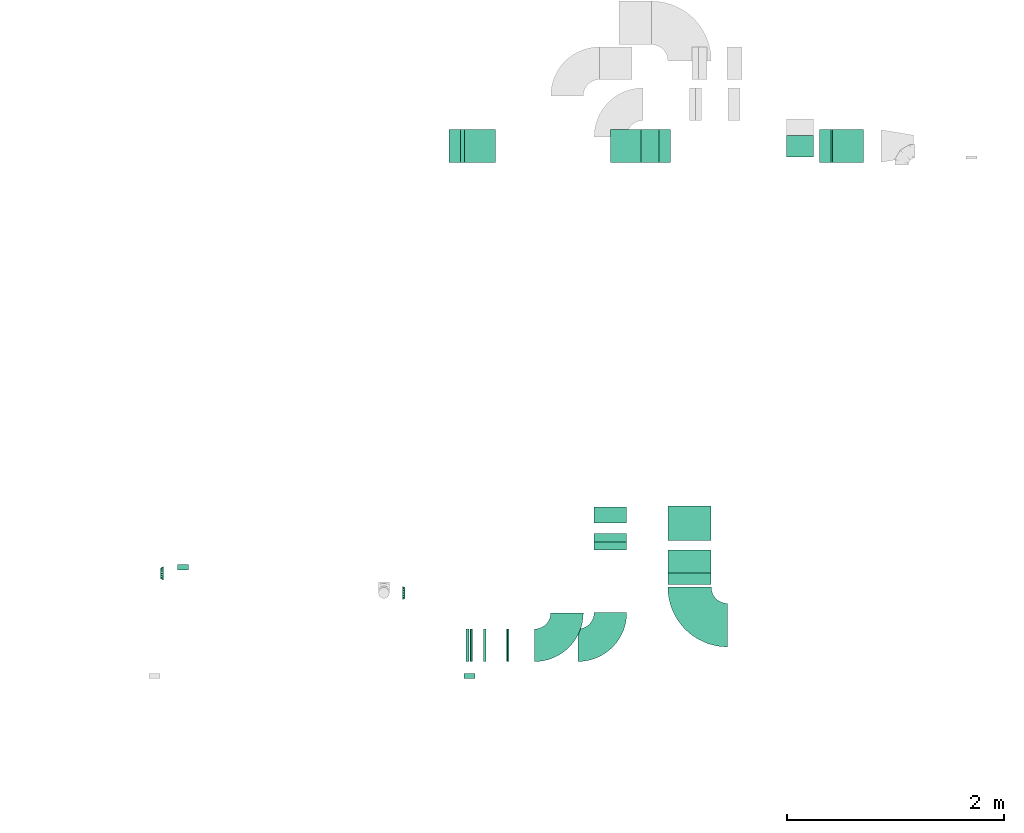
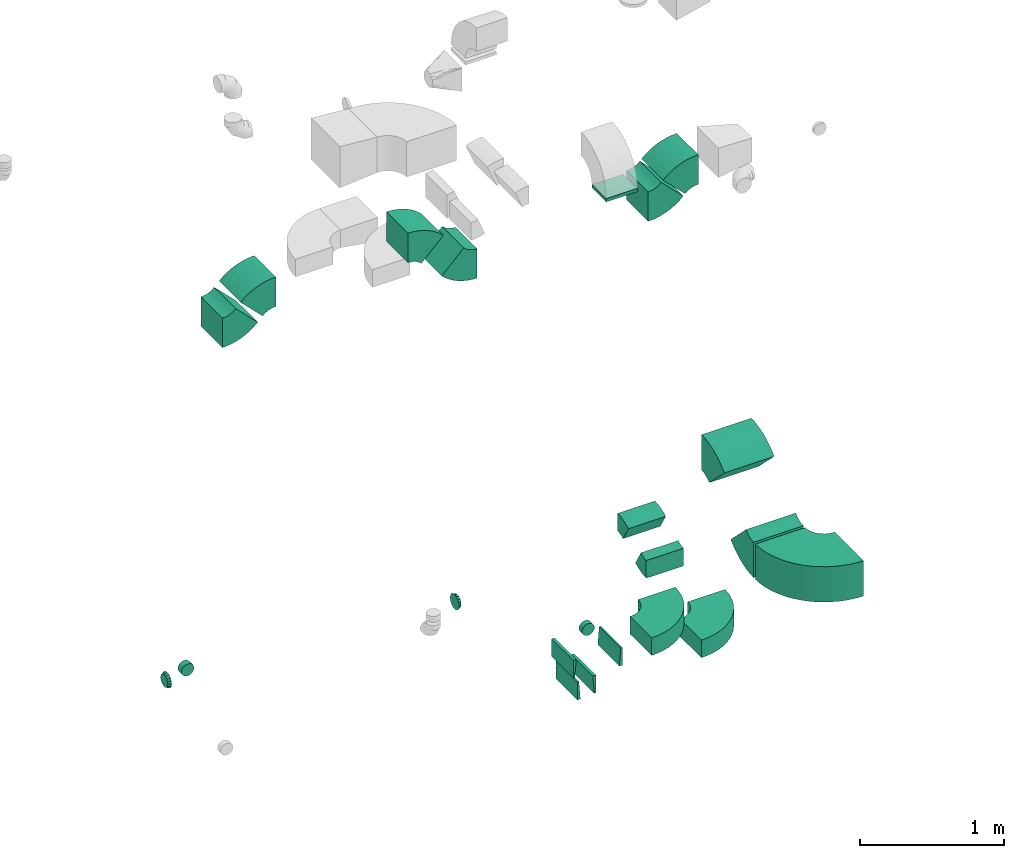
# One storey, part 19 of 44: 22 flow fittings.
"""IFC2X3 building model written with IfcOpenShell, lengths in millimetres."""

import ifcopenshell
import ifcopenshell.guid

model = None  # the IFC model being written
_history = None  # IfcOwnerHistory: only IFC2X3 demands one
_inside = {}  # id of a spatial element -> (the spatial element, [elements in it])
_under = {}  # id of a project, library or spatial element -> (it, [spatial elements below it])
_declared = {}  # id of a project -> (the project, [libraries it declares])
_typed = {}  # id of a type object -> (the type object, [elements of that type])
_made_of = {}  # id of a material, layer set ... -> (it, [elements and type objects made of it])


def new_model(schema):
    """Start an empty IFC model of exactly this schema.

    Asked for "IFC4X3", IfcOpenShell would pick the latest addendum, in which some entities
    have other attributes; the version numbers below select the first issue.
    IFC2X3 requires an IfcOwnerHistory on every rooted entity: one is made here for all.
    """
    global model, _history
    if schema == "IFC4X3":
        model = ifcopenshell.file(schema_version=(4, 3, 0, 0))
    else:
        model = ifcopenshell.file(schema=schema)
    _inside.clear()
    _under.clear()
    _declared.clear()
    _typed.clear()
    _made_of.clear()
    _history = None
    if model.schema == "IFC2X3":
        org = make("IfcOrganization", Name="unknown")
        user = make(
            "IfcPersonAndOrganization",
            ThePerson=make("IfcPerson", FamilyName="unknown"),
            TheOrganization=org,
        )
        app = make(
            "IfcApplication",
            ApplicationDeveloper=org,
            Version="unknown",
            ApplicationFullName="unknown",
            ApplicationIdentifier="unknown",
        )
        _history = make(
            "IfcOwnerHistory",
            OwningUser=user,
            OwningApplication=app,
            ChangeAction="ADDED",
            CreationDate=0,
        )
    return model


def make(cls, **values):
    """One entity of the class cls with the attributes given. An attribute that is None is left unset."""
    return model.create_entity(
        cls, **{name: value for name, value in values.items() if value is not None}
    )


def entity(cls, *values):
    """Any entity or typed value of the class cls, its attributes in the order of the schema. None: left unset."""
    e = model.create_entity(cls)
    for i, value in enumerate(values):
        if value is not None:
            e[i] = value
    return e


def rooted(cls, **values):
    """An entity with a GlobalId (a new one), such as an element, a storey or a relation."""
    return make(cls, GlobalId=ifcopenshell.guid.new(), OwnerHistory=_history, **values)


def si_unit(unit_type, name, prefix=None):
    """IfcSIUnit, for example si_unit("LENGTHUNIT", "METRE", prefix="MILLI")."""
    return make("IfcSIUnit", UnitType=unit_type, Prefix=prefix, Name=name)


def converted_unit(unit_type, name, factor, base, dimensions=None, offset=None):
    """IfcConversionBasedUnit, such as the inch: factor (a typed value) times the base unit."""
    return make(
        "IfcConversionBasedUnit"
        if offset is None
        else "IfcConversionBasedUnitWithOffset",
        ConversionOffset=offset,
        Dimensions=None
        if dimensions is None
        else entity("IfcDimensionalExponents", *dimensions),
        UnitType=unit_type,
        Name=name,
        ConversionFactor=make(
            "IfcMeasureWithUnit", ValueComponent=factor, UnitComponent=base
        ),
    )


def derived_unit(unit_type, elements):
    """IfcDerivedUnit: a product of units, each with its exponent."""
    return make(
        "IfcDerivedUnit",
        Elements=[
            make("IfcDerivedUnitElement", Unit=unit, Exponent=power)
            for unit, power in elements
        ],
        UnitType=unit_type,
    )


def assignment(units):
    """IfcUnitAssignment: the units of a project."""
    return None if units is None else make("IfcUnitAssignment", Units=units)


def point(xyz):
    """IfcCartesianPoint."""
    return None if xyz is None else make("IfcCartesianPoint", Coordinates=xyz)


def direction(xyz):
    """IfcDirection."""
    return None if xyz is None else make("IfcDirection", DirectionRatios=xyz)


def frame(location, z_axis=None, x_axis=None):
    """IfcAxis2Placement3D, a coordinate frame: its origin and axes. An axis left out is left unset."""
    return make(
        "IfcAxis2Placement3D",
        Location=point(location),
        Axis=direction(z_axis),
        RefDirection=direction(x_axis),
    )


def frame_2d(location, x_axis=None):
    """IfcAxis2Placement2D, a coordinate frame in the plane: its origin and x axis."""
    return make(
        "IfcAxis2Placement2D", Location=point(location), RefDirection=direction(x_axis)
    )


def origin():
    """The frame at (0, 0, 0) with its axes left unset."""
    return frame((0.0, 0.0, 0.0))


def origin_2d_with_axis():
    """The frame at (0, 0) in the plane with the x axis (1, 0) written out."""
    return frame_2d((0.0, 0.0), x_axis=(1.0, 0.0))


def place(relative_to, where):
    """IfcLocalPlacement: puts the frame where relative to a parent placement (None: the world)."""
    return make(
        "IfcLocalPlacement", PlacementRelTo=relative_to, RelativePlacement=where
    )


def context(
    kind, dimensions, precision=None, world=None, true_north=None, identifier=None
):
    """IfcGeometricRepresentationContext, for example the 3D "Model" context."""
    return make(
        "IfcGeometricRepresentationContext",
        ContextIdentifier=identifier,
        ContextType=kind,
        CoordinateSpaceDimension=dimensions,
        Precision=precision,
        WorldCoordinateSystem=world,
        TrueNorth=true_north,
    )


def subcontext(parent, identifier, kind, view, scale=None):
    """IfcGeometricRepresentationSubContext, for example "Body" below "Model"."""
    return make(
        "IfcGeometricRepresentationSubContext",
        ContextIdentifier=identifier,
        ContextType=kind,
        ParentContext=parent,
        TargetScale=scale,
        TargetView=view,
    )


def project(units=None, contexts=None):
    """IfcProject with its units and contexts."""
    return rooted(
        "IfcProject",
        Name="project",
        RepresentationContexts=contexts,
        UnitsInContext=assignment(units),
    )


def spatial(cls, under=None, at=None, **own):
    """A site, building, storey or space (cls), placed at a placement, below another one or the project."""
    s = rooted(cls, ObjectPlacement=at, **own)
    if under is not None:
        _under.setdefault(under.id(), (under, []))[1].append(s)
    return s


def polyline(points):
    """IfcPolyline through the points."""
    return make("IfcPolyline", Points=[point(p) for p in points])


def circle_curve(where, radius):
    """IfcCircle in the frame where."""
    return make("IfcCircle", Position=where, Radius=radius)


def parameter(value):
    """IfcParameterValue: where a trimmed curve begins or ends, as a parameter of its basis curve."""
    return model.create_entity("IfcParameterValue", value)


def trimmed(basis, trim1, trim2, sense, master):
    """IfcTrimmedCurve: the piece of a basis curve between two trims."""
    return make(
        "IfcTrimmedCurve",
        BasisCurve=basis,
        Trim1=trim1,
        Trim2=trim2,
        SenseAgreement=sense,
        MasterRepresentation=master,
    )


def segment(curve, same_sense, transition):
    """IfcCompositeCurveSegment."""
    return make(
        "IfcCompositeCurveSegment",
        Transition=transition,
        SameSense=same_sense,
        ParentCurve=curve,
    )


def composite_curve(segments, self_intersect=None):
    """IfcCompositeCurve: segments joined end to end."""
    return make("IfcCompositeCurve", Segments=segments, SelfIntersect=self_intersect)


def profile(cls, at=None, kind="AREA", **sizes):
    """A parametric profile (cls). Its sizes go by their IFC names, for example OverallWidth=200.0."""
    return make(cls, ProfileType=kind, Position=at, **sizes)


def rectangle(**sizes):
    """IfcRectangleProfileDef."""
    return profile("IfcRectangleProfileDef", **sizes)


def outline(outer, holes=None, kind="AREA"):
    """IfcArbitraryClosedProfileDef: a profile drawn as a closed curve; with holes, ...WithVoids."""
    if holes is None:
        return make("IfcArbitraryClosedProfileDef", ProfileType=kind, OuterCurve=outer)
    return make(
        "IfcArbitraryProfileDefWithVoids",
        ProfileType=kind,
        OuterCurve=outer,
        InnerCurves=holes,
    )


def extrude(swept, where, along, depth):
    """IfcExtrudedAreaSolid: the profile swept, set in the frame where, extruded along a direction by depth."""
    return make(
        "IfcExtrudedAreaSolid",
        SweptArea=swept,
        Position=where,
        ExtrudedDirection=direction(along),
        Depth=depth,
    )


def faces_of(points, faces, orient=None, outer=None):
    """IfcFace entities. A face is a list of loops; a loop is a list of indices into points, from 0.

    orient and outer hold one flag for each loop. By default every Orientation is true, the
    first loop of a face is its IfcFaceOuterBound and the others are IfcFaceBound.
    """
    made = []
    for i, loops in enumerate(faces):
        bounds = []
        for j, loop in enumerate(loops):
            is_outer = j == 0 if outer is None else outer[i][j]
            bounds.append(
                make(
                    "IfcFaceOuterBound" if is_outer else "IfcFaceBound",
                    Bound=make("IfcPolyLoop", Polygon=[points[k] for k in loop]),
                    Orientation=True if orient is None else orient[i][j],
                )
            )
        made.append(make("IfcFace", Bounds=bounds))
    return made


def faceted_brep(points, faces, orient=None, outer=None, voids=None):
    """IfcFacetedBrep: a solid bounded by flat faces; with voids (closed shells), ...WithVoids."""
    shared = [point(p) for p in points]
    hull = make("IfcClosedShell", CfsFaces=faces_of(shared, faces, orient, outer))
    if voids is None:
        return make("IfcFacetedBrep", Outer=hull)
    return make(
        "IfcFacetedBrepWithVoids",
        Outer=hull,
        Voids=[
            make(cls, CfsFaces=faces_of(shared, fs, o, b)) for cls, fs, o, b in voids
        ],
    )


def shape(context_of_items, identifier, shape_type, items):
    """IfcShapeRepresentation: the items that make up one representation, for example the "Body"."""
    return make(
        "IfcShapeRepresentation",
        ContextOfItems=context_of_items,
        RepresentationIdentifier=identifier,
        RepresentationType=shape_type,
        Items=items,
    )


def source(mapping_origin, context_of_items, identifier, shape_type, items):
    """IfcRepresentationMap: a shape defined once, which mapped items show again and again."""
    return make(
        "IfcRepresentationMap",
        MappingOrigin=mapping_origin,
        MappedRepresentation=shape(context_of_items, identifier, shape_type, items),
    )


def transform(
    local_origin,
    x_axis=None,
    y_axis=None,
    z_axis=None,
    scale=None,
    scale2=None,
    scale3=None,
    uniform=True,
):
    """IfcCartesianTransformationOperator3D, or its non-uniform kind. x_axis, y_axis, z_axis: its Axis1, 2, 3."""
    if uniform:
        return make(
            "IfcCartesianTransformationOperator3D",
            Axis1=direction(x_axis),
            Axis2=direction(y_axis),
            LocalOrigin=point(local_origin),
            Scale=scale,
            Axis3=direction(z_axis),
        )
    return make(
        "IfcCartesianTransformationOperator3DnonUniform",
        Axis1=direction(x_axis),
        Axis2=direction(y_axis),
        LocalOrigin=point(local_origin),
        Scale=scale,
        Axis3=direction(z_axis),
        Scale2=scale2,
        Scale3=scale3,
    )


def mapped(mapping_source, mapping_target):
    """IfcMappedItem: shows the shape of a source again, moved by a transform."""
    return make(
        "IfcMappedItem", MappingSource=mapping_source, MappingTarget=mapping_target
    )


def material(Name=None, Category=None):
    """IfcMaterial."""
    return make("IfcMaterial", Name=Name, Category=Category)


def made_of(thing, what):
    """Note that an element or type object is made of a material, layer set ...; save() writes the relation."""
    if what is not None:
        _made_of.setdefault(what.id(), (what, []))[1].append(thing)
    return thing


def type_object(cls, material=None, **own):
    """A type object (cls), such as IfcWallType, which elements share."""
    return made_of(rooted(cls, **own), material)


def type_shapes(of_type, sources):
    """Give a type object the sources (RepresentationMaps) that its elements show as mapped items."""
    of_type.RepresentationMaps = sources


def element(
    cls,
    number,
    at=None,
    inside=None,
    cuts=None,
    type_object=None,
    material=None,
    context=None,
    identifier="Body",
    shape_type=None,
    held_by="IfcProductDefinitionShape",
    body=None,
    shapes=None,
    **own,
):
    """One element of the class cls, such as IfcWall. Its Tag is "e" and its number.

    at: its placement. inside: the storey or other place that contains it. cuts: it is an
    opening in that element (IfcRelVoidsElement). A single representation is given by context,
    identifier, shape_type and body (its items); several are given by shapes. held_by: the class
    of the entity that holds the representations. save() writes the other relations.
    """
    e = rooted(cls, Tag="e%d" % number, ObjectPlacement=at, **own)
    if body is not None:
        shapes = [shape(context, identifier, shape_type, body)]
    if shapes is not None:
        e.Representation = make(held_by, Representations=shapes)
    if inside is not None:
        _inside.setdefault(inside.id(), (inside, []))[1].append(e)
    if cuts is not None:
        rooted(
            "IfcRelVoidsElement", RelatingBuildingElement=cuts, RelatedOpeningElement=e
        )
    if type_object is not None:
        _typed.setdefault(type_object.id(), (type_object, []))[1].append(e)
    return made_of(e, material)


def aggregate(whole, parts):
    """IfcRelAggregates: a whole, such as a stair, and the parts it consists of."""
    return rooted("IfcRelAggregates", RelatingObject=whole, RelatedObjects=parts)


def save(model, path):
    """Write the relations noted so far, then the file.

    IfcRelAggregates (storeys below a building ...), IfcRelContainedInSpatialStructure (elements
    in a storey), IfcRelDefinesByType, IfcRelAssociatesMaterial and IfcRelDeclares: one each for
    every whole, place, type object, material and project.
    """
    for whole, parts in _under.values():
        aggregate(whole, parts)
    for where, things in _inside.values():
        rooted(
            "IfcRelContainedInSpatialStructure",
            RelatedElements=things,
            RelatingStructure=where,
        )
    for kind, things in _typed.values():
        rooted("IfcRelDefinesByType", RelatedObjects=things, RelatingType=kind)
    for what, things in _made_of.values():
        rooted("IfcRelAssociatesMaterial", RelatedObjects=things, RelatingMaterial=what)
    for by, libraries in _declared.values():
        rooted("IfcRelDeclares", RelatingContext=by, RelatedDefinitions=libraries)
    model.write(path)


model = new_model("IFC2X3")

# Units and contexts
model_context = context("Model", 3, precision=0.01, world=origin(), true_north=direction((6.12303176911189e-17, 1.0)))
body_context = subcontext(model_context, "Body", "Model", "MODEL_VIEW")
ifc_project = project(units=[si_unit("LENGTHUNIT", "METRE", prefix="MILLI"), si_unit("AREAUNIT", "SQUARE_METRE"), si_unit("VOLUMEUNIT", "CUBIC_METRE"), converted_unit("PLANEANGLEUNIT", "DEGREE", entity("IfcRatioMeasure", 0.0174532925199433), si_unit("PLANEANGLEUNIT", "RADIAN"), dimensions=[0, 0, 0, 0, 0, 0, 0]), si_unit("MASSUNIT", "GRAM", prefix="KILO"), derived_unit("MASSDENSITYUNIT", [(si_unit("MASSUNIT", "GRAM", prefix="KILO"), 1), (si_unit("LENGTHUNIT", "METRE"), -3)]), derived_unit("MOMENTOFINERTIAUNIT", [(si_unit("LENGTHUNIT", "METRE"), 4)]), si_unit("TIMEUNIT", "SECOND"), si_unit("FREQUENCYUNIT", "HERTZ"), si_unit("THERMODYNAMICTEMPERATUREUNIT", "DEGREE_CELSIUS"), derived_unit("THERMALTRANSMITTANCEUNIT", [(si_unit("MASSUNIT", "GRAM", prefix="KILO"), 1), (si_unit("THERMODYNAMICTEMPERATUREUNIT", "KELVIN"), -1), (si_unit("TIMEUNIT", "SECOND"), -3)]), derived_unit("VOLUMETRICFLOWRATEUNIT", [(si_unit("LENGTHUNIT", "METRE"), 3), (si_unit("TIMEUNIT", "SECOND"), -1)]), derived_unit("MASSFLOWRATEUNIT", [(si_unit("MASSUNIT", "GRAM", prefix="KILO"), 1), (si_unit("TIMEUNIT", "SECOND"), -1)]), derived_unit("ROTATIONALFREQUENCYUNIT", [(si_unit("TIMEUNIT", "SECOND"), -1)]), si_unit("ELECTRICCURRENTUNIT", "AMPERE"), si_unit("ELECTRICVOLTAGEUNIT", "VOLT"), si_unit("POWERUNIT", "WATT"), si_unit("FORCEUNIT", "NEWTON", prefix="KILO"), si_unit("ILLUMINANCEUNIT", "LUX"), si_unit("LUMINOUSFLUXUNIT", "LUMEN"), si_unit("LUMINOUSINTENSITYUNIT", "CANDELA"), derived_unit("USERDEFINED", [(si_unit("MASSUNIT", "GRAM", prefix="KILO"), -1), (si_unit("LENGTHUNIT", "METRE"), -2), (si_unit("TIMEUNIT", "SECOND"), 3), (si_unit("LUMINOUSFLUXUNIT", "LUMEN"), 1)]), derived_unit("LINEARVELOCITYUNIT", [(si_unit("LENGTHUNIT", "METRE"), 1), (si_unit("TIMEUNIT", "SECOND"), -1)]), si_unit("PRESSUREUNIT", "PASCAL"), derived_unit("USERDEFINED", [(si_unit("LENGTHUNIT", "METRE"), -2), (si_unit("MASSUNIT", "GRAM", prefix="KILO"), 1), (si_unit("TIMEUNIT", "SECOND"), -2)]), derived_unit("LINEARFORCEUNIT", [(si_unit("MASSUNIT", "GRAM", prefix="KILO"), 1), (si_unit("LENGTHUNIT", "METRE"), 1), (si_unit("TIMEUNIT", "SECOND"), -2), (si_unit("LENGTHUNIT", "METRE"), -1)]), derived_unit("PLANARFORCEUNIT", [(si_unit("MASSUNIT", "GRAM", prefix="KILO"), 1), (si_unit("LENGTHUNIT", "METRE"), 1), (si_unit("TIMEUNIT", "SECOND"), -2), (si_unit("LENGTHUNIT", "METRE"), -2)])], contexts=[model_context])

# Site, building, storey
site_placement = place(None, origin())
site = spatial("IfcSite", under=ifc_project, at=site_placement, CompositionType="ELEMENT")
building_placement = place(site_placement, origin())
building = spatial("IfcBuilding", under=site, at=building_placement, CompositionType="ELEMENT")
storey_placement = place(building_placement, frame((0.0, 0.0, 15900.0)))
storey = spatial("IfcBuildingStorey", under=building, at=storey_placement, CompositionType="ELEMENT", Elevation=15900.0)

# Flow fittings
ifc_material = material()
duct_fitting_type_1 = type_object("IfcDuctFittingType", PredefinedType="NOTDEFINED", material=ifc_material)
shared_shape_1 = source(origin(), body_context, "Body", "SweptSolid", [
    extrude(rectangle(XDim=26.096000000009, YDim=250.0, at=origin_2d_with_axis()), frame((6.95, 0.0, -100.0)), (0.0, 0.0, 1.0), 200.0),
])
type_shapes(duct_fitting_type_1, [shared_shape_1])
flow_fitting_1_placement = place(storey_placement, frame((39464.82, 14174.64, 3075.0), z_axis=(0.0, -1.0, 0.0), x_axis=(0.0, 0.0, 1.0)))
element("IfcFlowFitting", 1, at=flow_fitting_1_placement, inside=storey, type_object=duct_fitting_type_1, material=ifc_material, context=body_context, shape_type="MappedRepresentation", body=[
    mapped(shared_shape_1, transform((0.0, 0.0, 0.0), scale=1.0)),
])
duct_fitting_type_2 = type_object("IfcDuctFittingType", PredefinedType="NOTDEFINED", material=ifc_material)
shared_shape_2 = source(origin(), body_context, "Body", "Brep", [
    faceted_brep([(20.0, 12.94, -48.3), (20.0, 25.0, -43.3), (20.0, 35.36, -35.36), (20.0, 43.3, -25.0), (20.0, 48.3, -12.94), (20.0, 50.0, 0.0), (20.0, 48.3, 12.94), (20.0, 43.3, 25.0), (20.0, 35.36, 35.36), (20.0, 25.0, 43.3), (20.0, 12.94, 48.3), (20.0, 0.0, 50.0), (20.0, -12.94, 48.3), (20.0, -25.0, 43.3), (20.0, -35.36, 35.36), (20.0, -43.3, 25.0), (20.0, -48.3, 12.94), (20.0, -50.0, 0.0), (20.0, -48.3, -12.94), (20.0, -43.3, -25.0), (20.0, -35.36, -35.36), (20.0, -25.0, -43.3), (20.0, -12.94, -48.3), (20.0, 0.0, -50.0), (0.0, 0.0, 50.0), (0.0, 12.94, 48.3), (-23.65, 12.94, 48.3), (-23.65, 0.0, 50.0), (0.0, 25.0, 43.3), (-23.65, 25.0, 43.3), (0.0, 35.36, 35.36), (-23.65, 35.36, 35.36), (0.0, 43.3, 25.0), (0.0, 48.3, 12.94), (-23.65, 48.3, 12.94), (-23.65, 43.3, 25.0), (0.0, 50.0, 0.0), (-23.65, 50.0, 0.0), (0.0, 48.3, -12.94), (-23.65, 48.3, -12.94), (0.0, 43.3, -25.0), (-23.65, 43.3, -25.0), (0.0, 35.36, -35.36), (-23.65, 35.36, -35.36), (0.0, 25.0, -43.3), (0.0, 12.94, -48.3), (-23.65, 12.94, -48.3), (-23.65, 25.0, -43.3), (0.0, 0.0, -50.0), (-23.65, 0.0, -50.0), (0.0, -12.94, -48.3), (-23.65, -12.94, -48.3), (0.0, -25.0, -43.3), (-23.65, -25.0, -43.3), (0.0, -35.36, -35.36), (-23.65, -35.36, -35.36), (0.0, -43.3, -25.0), (0.0, -48.3, -12.94), (-23.65, -48.3, -12.94), (-23.65, -43.3, -25.0), (0.0, -50.0, 0.0), (-23.65, -50.0, 0.0), (0.0, -48.3, 12.94), (-23.65, -48.3, 12.94), (0.0, -43.3, 25.0), (-23.65, -43.3, 25.0), (0.0, -35.36, 35.36), (-23.65, -35.36, 35.36), (0.0, -25.0, 43.3), (0.0, -12.94, 48.3), (-23.65, -12.94, 48.3), (-23.65, -25.0, 43.3)], [[[0, 1, 2, 3, 4, 5, 6, 7, 8, 9, 10, 11, 12, 13, 14, 15, 16, 17, 18, 19, 20, 21, 22, 23]], [[24, 11, 10, 25, 26, 27]], [[25, 10, 9, 28, 29, 26]], [[28, 9, 8, 30, 31, 29]], [[32, 7, 6, 33, 34, 35]], [[33, 6, 5, 36, 37, 34]], [[30, 8, 7, 32, 35, 31]], [[36, 5, 4, 38, 39, 37]], [[38, 4, 3, 40, 41, 39]], [[40, 3, 2, 42, 43, 41]], [[44, 1, 0, 45, 46, 47]], [[45, 0, 23, 48, 49, 46]], [[42, 2, 1, 44, 47, 43]], [[48, 23, 22, 50, 51, 49]], [[50, 22, 21, 52, 53, 51]], [[52, 21, 20, 54, 55, 53]], [[56, 19, 18, 57, 58, 59]], [[57, 18, 17, 60, 61, 58]], [[54, 20, 19, 56, 59, 55]], [[60, 17, 16, 62, 63, 61]], [[62, 16, 15, 64, 65, 63]], [[64, 15, 14, 66, 67, 65]], [[68, 13, 12, 69, 70, 71]], [[69, 12, 11, 24, 27, 70]], [[66, 14, 13, 68, 71, 67]], [[49, 51, 53, 55, 59, 58, 61, 63, 65, 67, 71, 70, 27, 26, 29, 31, 35, 34, 37, 39, 41, 43, 47, 46]]]),
])
type_shapes(duct_fitting_type_2, [shared_shape_2])
flow_fitting_2_placement = place(storey_placement, frame((36421.31, 9290.12, 3375.0), z_axis=(0.0, 0.0, -1.0), x_axis=(0.0, -1.0, 0.0)))
element("IfcFlowFitting", 2, at=flow_fitting_2_placement, inside=storey, type_object=duct_fitting_type_2, material=ifc_material, context=body_context, shape_type="MappedRepresentation", body=[
    mapped(shared_shape_2, transform((0.0, 0.0, 0.0), scale=1.0)),
])
duct_fitting_type_3 = type_object("IfcDuctFittingType", PredefinedType="NOTDEFINED", material=ifc_material)
shared_shape_3 = source(origin(), body_context, "Body", "Brep", [
    faceted_brep([(25.0, -46.19, 19.13), (25.0, -48.1, 9.57), (25.0, -50.0, 0.0), (25.0, -48.1, -9.57), (25.0, -46.19, -19.13), (25.0, -40.77, -27.24), (25.0, -35.36, -35.36), (25.0, -27.24, -40.77), (25.0, -19.13, -46.19), (25.0, -9.57, -48.1), (25.0, 0.0, -50.0), (25.0, 9.57, -48.1), (25.0, 19.13, -46.19), (25.0, 27.24, -40.77), (25.0, 35.36, -35.36), (25.0, 40.77, -27.24), (25.0, 46.19, -19.13), (25.0, 48.1, -9.57), (25.0, 50.0, 0.0), (25.0, 48.1, 9.57), (25.0, 46.19, 19.13), (25.0, 40.77, 27.24), (25.0, 35.36, 35.36), (25.0, 27.24, 40.77), (25.0, 19.13, 46.19), (25.0, 9.57, 48.1), (25.0, 0.0, 50.0), (25.0, -9.57, 48.1), (25.0, -19.13, 46.19), (25.0, -27.24, 40.77), (25.0, -35.36, 35.36), (25.0, -40.77, 27.24), (0.0, -62.5, 0.0), (0.0, -60.02, 12.45), (0.0, -57.74, 23.92), (0.0, -50.97, 34.06), (0.0, -44.19, 44.19), (0.0, -34.06, 50.97), (0.0, -23.92, 57.74), (0.0, -12.45, 60.02), (0.0, 0.0, 62.5), (0.0, 12.45, 60.02), (0.0, 23.92, 57.74), (0.0, 34.06, 50.97), (0.0, 44.19, 44.19), (0.0, 50.97, 34.06), (0.0, 57.74, 23.92), (0.0, 60.02, 12.45), (0.0, 62.5, 0.0), (0.0, 60.02, -12.45), (0.0, 57.74, -23.92), (0.0, 50.97, -34.06), (0.0, 44.19, -44.19), (0.0, 34.06, -50.97), (0.0, 23.92, -57.74), (0.0, 12.45, -60.02), (0.0, 0.0, -62.5), (0.0, -12.45, -60.02), (0.0, -23.92, -57.74), (0.0, -34.06, -50.97), (0.0, -44.19, -44.19), (0.0, -50.97, -34.06), (0.0, -57.74, -23.92), (0.0, -60.02, -12.45)], [[[0, 1, 2, 3, 4, 5, 6, 7, 8, 9, 10, 11, 12, 13, 14, 15, 16, 17, 18, 19, 20, 21, 22, 23, 24, 25, 26, 27, 28, 29, 30, 31]], [[32, 33, 34, 35, 36, 37, 38, 39, 40, 41, 42, 43, 44, 45, 46, 47, 48, 49, 50, 51, 52, 53, 54, 55, 56, 57, 58, 59, 60, 61, 62, 63]], [[24, 42, 41, 40, 26, 25]], [[22, 44, 43, 42, 24, 23]], [[48, 47, 46, 20, 19, 18]], [[44, 22, 21, 20, 46, 45]], [[0, 34, 33, 32, 2, 1]], [[30, 36, 35, 34, 0, 31]], [[40, 39, 38, 28, 27, 26]], [[36, 30, 29, 28, 38, 37]], [[8, 58, 57, 56, 10, 9]], [[6, 60, 59, 58, 8, 7]], [[32, 63, 62, 4, 3, 2]], [[60, 6, 5, 4, 62, 61]], [[16, 50, 49, 48, 18, 17]], [[14, 52, 51, 50, 16, 15]], [[56, 55, 54, 12, 11, 10]], [[52, 14, 13, 12, 54, 53]]]),
])
type_shapes(duct_fitting_type_3, [shared_shape_3])
flow_fitting_3_placement = place(storey_placement, frame((33599.89, 10237.4, 3350.0), z_axis=(0.0, 0.0, 1.0), x_axis=(-1.0, 0.0, 0.0)))
element("IfcFlowFitting", 3, at=flow_fitting_3_placement, inside=storey, type_object=duct_fitting_type_3, material=ifc_material, context=body_context, shape_type="MappedRepresentation", body=[
    mapped(shared_shape_3, transform((0.0, 0.0, 0.0), scale=1.0)),
])
duct_fitting_type_4 = type_object("IfcDuctFittingType", PredefinedType="NOTDEFINED", material=ifc_material)
shared_shape_4 = source(origin(), body_context, "Body", "Brep", [
    faceted_brep([(25.0, 0.0, -62.5), (25.0, 12.45, -60.02), (25.0, 23.92, -57.74), (25.0, 34.06, -50.97), (25.0, 44.19, -44.19), (25.0, 50.97, -34.06), (25.0, 57.74, -23.92), (25.0, 60.02, -12.45), (25.0, 62.5, 0.0), (25.0, 60.02, 12.45), (25.0, 57.74, 23.92), (25.0, 50.97, 34.06), (25.0, 44.19, 44.19), (25.0, 34.06, 50.97), (25.0, 23.92, 57.74), (25.0, 12.45, 60.02), (25.0, 0.0, 62.5), (25.0, -12.45, 60.02), (25.0, -23.92, 57.74), (25.0, -34.06, 50.97), (25.0, -44.19, 44.19), (25.0, -50.97, 34.06), (25.0, -57.74, 23.92), (25.0, -60.02, 12.45), (25.0, -62.5, 0.0), (25.0, -60.02, -12.45), (25.0, -57.74, -23.92), (25.0, -50.97, -34.06), (25.0, -44.19, -44.19), (25.0, -34.06, -50.97), (25.0, -23.92, -57.74), (25.0, -12.45, -60.02), (0.0, -19.13, -46.19), (0.0, -27.24, -40.77), (0.0, -35.36, -35.36), (0.0, -40.77, -27.24), (0.0, -46.19, -19.13), (0.0, -48.1, -9.57), (0.0, -50.0, 0.0), (0.0, -48.1, 9.57), (0.0, -46.19, 19.13), (0.0, -40.77, 27.24), (0.0, -35.36, 35.36), (0.0, -27.24, 40.77), (0.0, -19.13, 46.19), (0.0, -9.57, 48.1), (0.0, 0.0, 50.0), (0.0, 9.57, 48.1), (0.0, 19.13, 46.19), (0.0, 27.24, 40.77), (0.0, 35.36, 35.36), (0.0, 40.77, 27.24), (0.0, 46.19, 19.13), (0.0, 48.1, 9.57), (0.0, 50.0, 0.0), (0.0, 48.1, -9.57), (0.0, 46.19, -19.13), (0.0, 40.77, -27.24), (0.0, 35.36, -35.36), (0.0, 27.24, -40.77), (0.0, 19.13, -46.19), (0.0, 9.57, -48.1), (0.0, 0.0, -50.0), (0.0, -9.57, -48.1)], [[[0, 1, 2, 3, 4, 5, 6, 7, 8, 9, 10, 11, 12, 13, 14, 15, 16, 17, 18, 19, 20, 21, 22, 23, 24, 25, 26, 27, 28, 29, 30, 31]], [[32, 33, 34, 35, 36, 37, 38, 39, 40, 41, 42, 43, 44, 45, 46, 47, 48, 49, 50, 51, 52, 53, 54, 55, 56, 57, 58, 59, 60, 61, 62, 63]], [[52, 10, 9, 8, 54, 53]], [[51, 50, 12, 11, 10, 52]], [[47, 46, 16, 15, 14, 48]], [[49, 48, 14, 13, 12, 50]], [[44, 18, 17, 16, 46, 45]], [[43, 42, 20, 19, 18, 44]], [[39, 38, 24, 23, 22, 40]], [[41, 40, 22, 21, 20, 42]], [[36, 26, 25, 24, 38, 37]], [[35, 34, 28, 27, 26, 36]], [[63, 62, 0, 31, 30, 32]], [[33, 32, 30, 29, 28, 34]], [[60, 2, 1, 0, 62, 61]], [[59, 58, 4, 3, 2, 60]], [[55, 54, 8, 7, 6, 56]], [[57, 56, 6, 5, 4, 58]]]),
])
type_shapes(duct_fitting_type_4, [shared_shape_4])
flow_fitting_4_placement = place(storey_placement, frame((35827.51, 10057.12, 3350.0), z_axis=(0.0, 0.0, 1.0), x_axis=(-1.0, 0.0, 0.0)))
element("IfcFlowFitting", 4, at=flow_fitting_4_placement, inside=storey, type_object=duct_fitting_type_4, material=ifc_material, context=body_context, shape_type="MappedRepresentation", body=[
    mapped(shared_shape_4, transform((0.0, 0.0, 0.0), scale=1.0)),
])
duct_fitting_type_5 = type_object("IfcDuctFittingType", PredefinedType="NOTDEFINED", material=ifc_material)
shared_shape_5 = source(origin(), body_context, "Body", "Brep", [
    faceted_brep([(20.0, 0.0, -50.0), (20.0, 12.94, -48.3), (20.0, 25.0, -43.3), (20.0, 35.36, -35.36), (20.0, 43.3, -25.0), (20.0, 48.3, -12.94), (20.0, 50.0, 0.0), (20.0, 48.3, 12.94), (20.0, 43.3, 25.0), (20.0, 35.36, 35.36), (20.0, 25.0, 43.3), (20.0, 12.94, 48.3), (20.0, 0.0, 50.0), (20.0, -12.94, 48.3), (20.0, -25.0, 43.3), (20.0, -35.36, 35.36), (20.0, -43.3, 25.0), (20.0, -48.3, 12.94), (20.0, -50.0, 0.0), (20.0, -48.3, -12.94), (20.0, -43.3, -25.0), (20.0, -35.36, -35.36), (20.0, -25.0, -43.3), (20.0, -12.94, -48.3), (0.0, 0.0, 50.0), (-31.1, 0.0, 50.0), (-31.1, -12.94, 48.3), (0.0, -12.94, 48.3), (-31.1, -25.0, 43.3), (0.0, -25.0, 43.3), (0.0, -35.36, 35.36), (-31.1, -35.36, 35.36), (0.0, -43.3, 25.0), (-31.1, -43.3, 25.0), (-31.1, -48.3, 12.94), (0.0, -48.3, 12.94), (-31.1, -50.0, 0.0), (0.0, -50.0, 0.0), (-31.1, -48.3, -12.94), (0.0, -48.3, -12.94), (-31.1, -43.3, -25.0), (0.0, -43.3, -25.0), (0.0, -35.36, -35.36), (-31.1, -35.36, -35.36), (0.0, -25.0, -43.3), (-31.1, -25.0, -43.3), (-31.1, -12.94, -48.3), (0.0, -12.94, -48.3), (-31.1, 0.0, -50.0), (0.0, 0.0, -50.0), (-31.1, 12.94, -48.3), (0.0, 12.94, -48.3), (-31.1, 25.0, -43.3), (0.0, 25.0, -43.3), (0.0, 35.36, -35.36), (-31.1, 35.36, -35.36), (0.0, 43.3, -25.0), (-31.1, 43.3, -25.0), (-31.1, 48.3, -12.94), (0.0, 48.3, -12.94), (-31.1, 50.0, 0.0), (0.0, 50.0, 0.0), (-31.1, 48.3, 12.94), (0.0, 48.3, 12.94), (-31.1, 43.3, 25.0), (0.0, 43.3, 25.0), (0.0, 35.36, 35.36), (-31.1, 35.36, 35.36), (0.0, 25.0, 43.3), (-31.1, 25.0, 43.3), (-31.1, 12.94, 48.3), (0.0, 12.94, 48.3)], [[[0, 1, 2, 3, 4, 5, 6, 7, 8, 9, 10, 11, 12, 13, 14, 15, 16, 17, 18, 19, 20, 21, 22, 23]], [[13, 12, 24, 25, 26, 27]], [[14, 13, 27, 26, 28, 29]], [[30, 15, 14, 29, 28, 31]], [[17, 16, 32, 33, 34, 35]], [[18, 17, 35, 34, 36, 37]], [[32, 16, 15, 30, 31, 33]], [[19, 18, 37, 36, 38, 39]], [[20, 19, 39, 38, 40, 41]], [[42, 21, 20, 41, 40, 43]], [[23, 22, 44, 45, 46, 47]], [[0, 23, 47, 46, 48, 49]], [[44, 22, 21, 42, 43, 45]], [[1, 0, 49, 48, 50, 51]], [[2, 1, 51, 50, 52, 53]], [[54, 3, 2, 53, 52, 55]], [[5, 4, 56, 57, 58, 59]], [[6, 5, 59, 58, 60, 61]], [[56, 4, 3, 54, 55, 57]], [[7, 6, 61, 60, 62, 63]], [[8, 7, 63, 62, 64, 65]], [[66, 9, 8, 65, 64, 67]], [[11, 10, 68, 69, 70, 71]], [[12, 11, 71, 70, 25, 24]], [[68, 10, 9, 66, 67, 69]], [[46, 45, 43, 40, 38, 36, 34, 33, 31, 28, 26, 25, 70, 69, 67, 64, 62, 60, 58, 57, 55, 52, 50, 48]]]),
])
type_shapes(duct_fitting_type_5, [shared_shape_5])
flow_fitting_5_placement = place(storey_placement, frame((33782.61, 10299.9, 3350.0), z_axis=(0.0, 0.0, -1.0), x_axis=(0.0, 1.0, 0.0)))
element("IfcFlowFitting", 5, at=flow_fitting_5_placement, inside=storey, type_object=duct_fitting_type_5, material=ifc_material, context=body_context, shape_type="MappedRepresentation", body=[
    mapped(shared_shape_5, transform((0.0, 0.0, 0.0), scale=1.0)),
])
duct_fitting_type_6 = type_object("IfcDuctFittingType", PredefinedType="NOTDEFINED", material=ifc_material)
shared_shape_6 = source(origin(), body_context, "Body", "SweptSolid", [
    extrude(outline(composite_curve([segment(polyline([(-300.0, -150.0), (0.0, -150.0)]), True, "CONTINUOUS"), segment(trimmed(circle_curve(frame_2d((150.0, -150.0), x_axis=(0.0, 1.0)), 150.0), [parameter(0.0)], [parameter(90.0)], True, "PARAMETER"), False, "CONTINUOUS"), segment(polyline([(150.0, 0.0), (150.0, 300.0)]), True, "CONTINUOUS"), segment(trimmed(circle_curve(frame_2d((150.0, -150.0), x_axis=(0.0, 1.0)), 450.0), [parameter(0.0)], [parameter(90.0000000000001)], True, "PARAMETER"), True, "CONTINUOUS")], self_intersect=False)), frame((-150.0, 150.0, -75.0), z_axis=(0.0, 0.0, 1.0), x_axis=(-1.0, 0.0, 0.0)), (0.0, 0.0, 1.0), 150.0),
])
type_shapes(duct_fitting_type_6, [shared_shape_6])
for number, where in (
    (6, (37320.11, 9575.09, 2925.0)),
    (7, (37720.04, 9575.61, 2765.0)),
):
    element("IfcFlowFitting", number, at=place(storey_placement, frame(where)), inside=storey, type_object=duct_fitting_type_6, material=ifc_material, context=body_context, shape_type="MappedRepresentation", body=[
        mapped(shared_shape_6, transform((0.0, 0.0, 0.0), scale=1.0)),
    ])
duct_fitting_type_7 = type_object("IfcDuctFittingType", PredefinedType="NOTDEFINED", material=ifc_material)
shared_shape_7 = source(origin(), body_context, "Body", "SweptSolid", [
    extrude(outline(composite_curve([segment(polyline([(-375.0, -175.0), (25.0, -175.0)]), True, "CONTINUOUS"), segment(trimmed(circle_curve(frame_2d((175.0, -175.0), x_axis=(0.0, 1.0)), 150.0), [parameter(0.0)], [parameter(90.0000000000001)], True, "PARAMETER"), False, "CONTINUOUS"), segment(polyline([(175.0, -25.0), (175.0, 375.0)]), True, "CONTINUOUS"), segment(trimmed(circle_curve(frame_2d((175.0, -175.0), x_axis=(0.0, 1.0)), 550.0), [parameter(0.0)], [parameter(90.0)], True, "PARAMETER"), True, "CONTINUOUS")], self_intersect=False)), frame((-175.0, 175.0, -150.0), z_axis=(0.0, 0.0, 1.0), x_axis=(-1.0, 0.0, 0.0)), (0.0, 0.0, 1.0), 300.0),
])
type_shapes(duct_fitting_type_7, [shared_shape_7])
flow_fitting_6_placement = place(storey_placement, frame((38448.74, 9760.56, 2800.0), z_axis=(0.0, 0.0, 1.0), x_axis=(0.0, -1.0, 0.0)))
element("IfcFlowFitting", 8, at=flow_fitting_6_placement, inside=storey, type_object=duct_fitting_type_7, material=ifc_material, context=body_context, shape_type="MappedRepresentation", body=[
    mapped(shared_shape_7, transform((0.0, 0.0, 0.0), scale=1.0)),
])
duct_fitting_type_8 = type_object("IfcDuctFittingType", PredefinedType="NOTDEFINED", material=ifc_material)
shared_shape_8 = source(origin(), body_context, "Body", "SweptSolid", [
    extrude(outline(composite_curve([segment(polyline([(-193.93, -106.07), (106.07, -106.07)]), True, "CONTINUOUS"), segment(trimmed(circle_curve(frame_2d((256.07, -106.07), x_axis=(-0.707106781186553, 0.707106781186553)), 150.0), [parameter(0.0)], [parameter(45.0)], True, "PARAMETER"), False, "CONTINUOUS"), segment(polyline([(150.0, 0.0), (-62.13, 212.13)]), True, "CONTINUOUS"), segment(trimmed(circle_curve(frame_2d((256.07, -106.07), x_axis=(-0.707106781186553, 0.707106781186553)), 450.0), [parameter(0.0)], [parameter(45.0)], True, "PARAMETER"), True, "CONTINUOUS")], self_intersect=False)), frame((-18.2, 43.93, -200.0), z_axis=(0.0, 0.0, 1.0), x_axis=(-0.707106781186547, 0.707106781186548, 0.0)), (0.0, 0.0, 1.0), 400.0),
])
type_shapes(duct_fitting_type_8, [shared_shape_8])
for number, where, z_axis, x_axis in (
    (9, (38448.74, 10735.0, 3275.0), (1.0, 0.0, 0.0), (0.0, -1.0, 0.0)),
    (10, (38448.74, 10260.0, 2800.0), (1.0, 0.0, 0.0), (0.0, 1.0, 0.0)),
):
    element("IfcFlowFitting", number, at=place(storey_placement, frame(where, z_axis=z_axis, x_axis=x_axis)), inside=storey, type_object=duct_fitting_type_8, material=ifc_material, context=body_context, shape_type="MappedRepresentation", body=[
        mapped(shared_shape_8, transform((0.0, 0.0, 0.0), scale=1.0)),
    ])
duct_fitting_type_9 = type_object("IfcDuctFittingType", PredefinedType="NOTDEFINED", material=ifc_material)
shared_shape_9 = source(origin(), body_context, "Body", "SweptSolid", [
    extrude(outline(composite_curve([segment(polyline([(-165.27, -97.23), (84.73, -97.23)]), True, "CONTINUOUS"), segment(trimmed(circle_curve(frame_2d((234.73, -97.23), x_axis=(-0.707106781186546, 0.707106781186546)), 150.0), [parameter(0.0)], [parameter(45.0)], True, "PARAMETER"), False, "CONTINUOUS"), segment(polyline([(128.66, 8.84), (-48.12, 185.62)]), True, "CONTINUOUS"), segment(trimmed(circle_curve(frame_2d((234.73, -97.23), x_axis=(-0.707106781186546, 0.707106781186546)), 400.0), [parameter(0.0)], [parameter(45.0)], True, "PARAMETER"), True, "CONTINUOUS")], self_intersect=False)), frame((-16.68, 40.27, -150.0), z_axis=(0.0, 0.0, 1.0), x_axis=(-0.707106781186547, 0.707106781186548, 0.0)), (0.0, 0.0, 1.0), 300.0),
])
type_shapes(duct_fitting_type_9, [shared_shape_9])
for number, where, z_axis, x_axis in (
    (11, (36344.82, 14175.53, 3075.0), (0.0, -1.0, 0.0), (1.0, 0.0, 0.0)),
    (12, (36544.82, 14175.53, 3275.0), (0.0, 1.0, 0.0), (0.70710678118641, 0.0, 0.707106781186685)),
    (13, (37834.82, 14175.53, 3275.0), (0.0, 1.0, 0.0), (1.0, 0.0, 0.0)),
    (14, (38159.82, 14175.53, 2950.0), (0.0, -1.0, 0.0), (0.707106781186538, 0.0, -0.707106781186557)),
    (15, (39761.98, 14175.53, 2950.0), (0.0, -1.0, 0.0), (1.0, 0.0, 0.0)),
    (16, (39936.98, 14175.53, 3125.0), (0.0, 1.0, 0.0), (0.707106781186541, 0.0, 0.707106781186555)),
):
    element("IfcFlowFitting", number, at=place(storey_placement, frame(where, z_axis=z_axis, x_axis=x_axis)), inside=storey, type_object=duct_fitting_type_9, material=ifc_material, context=body_context, shape_type="MappedRepresentation", body=[
        mapped(shared_shape_9, transform((0.0, 0.0, 0.0), scale=1.0)),
    ])
duct_fitting_type_10 = type_object("IfcDuctFittingType", PredefinedType="NOTDEFINED", material=ifc_material)
shared_shape_10 = source(origin(), body_context, "Body", "SweptSolid", [
    extrude(outline(composite_curve([segment(polyline([(-75.36, -8.97), (74.64, -8.97)]), True, "CONTINUOUS"), segment(trimmed(circle_curve(frame_2d((224.64, -8.97), x_axis=(-0.996815278738975, 0.0797452197472638)), 150.0), [parameter(0.0)], [parameter(4.57392111415604)], True, "PARAMETER"), False, "CONTINUOUS"), segment(polyline([(75.12, 2.99), (-74.4, 14.95)]), True, "CONTINUOUS"), segment(trimmed(circle_curve(frame_2d((224.64, -8.97), x_axis=(-0.996815278738975, 0.0797452197472638)), 300.0), [parameter(0.0)], [parameter(4.57392111415604)], True, "PARAMETER"), True, "CONTINUOUS")], self_intersect=False)), frame((-0.01, 0.36, -150.0), z_axis=(0.0, 0.0, 1.0), x_axis=(-0.0797452197472641, 0.996815278738975, 0.0)), (0.0, 0.0, 1.0), 300.0),
])
type_shapes(duct_fitting_type_10, [shared_shape_10])
for number, where, z_axis, x_axis in (
    (17, (36775.13, 9575.09, 2925.0), (0.0, 1.0, 0.0), (-1.0, 0.0, 0.0)),
    (18, (36400.13, 9575.09, 2955.0), (0.0, -1.0, 0.0), (-0.996815278738973, 0.0, 0.0797452197472883)),
):
    element("IfcFlowFitting", number, at=place(storey_placement, frame(where, z_axis=z_axis, x_axis=x_axis)), inside=storey, type_object=duct_fitting_type_10, material=ifc_material, context=body_context, shape_type="MappedRepresentation", body=[
        mapped(shared_shape_10, transform((0.0, 0.0, 0.0), scale=1.0)),
    ])
duct_fitting_type_11 = type_object("IfcDuctFittingType", PredefinedType="NOTDEFINED", material=ifc_material)
shared_shape_11 = source(origin(), body_context, "Body", "SweptSolid", [
    extrude(outline(composite_curve([segment(polyline([(-90.07, -56.25), (59.93, -56.25)]), True, "CONTINUOUS"), segment(trimmed(circle_curve(frame_2d((209.93, -56.25), x_axis=(-0.866025403784439, 0.499999999999998)), 150.0), [parameter(0.0)], [parameter(29.9999999999999)], True, "PARAMETER"), False, "CONTINUOUS"), segment(polyline([(80.02, 18.75), (-49.88, 93.75)]), True, "CONTINUOUS"), segment(trimmed(circle_curve(frame_2d((209.93, -56.25), x_axis=(-0.866025403784439, 0.499999999999998)), 300.0), [parameter(0.0)], [parameter(29.9999999999999)], True, "PARAMETER"), True, "CONTINUOUS")], self_intersect=False)), frame((-4.04, 15.07, -150.0), z_axis=(0.0, 0.0, 1.0), x_axis=(-0.499999999999999, 0.866025403784439, 0.0)), (0.0, 0.0, 1.0), 300.0),
])
type_shapes(duct_fitting_type_11, [shared_shape_11])
for number, where, z_axis, x_axis in (
    (19, (37720.04, 10790.56, 2925.0), (1.0, 0.0, 0.0), (0.0, -1.0, 0.0)),
    (20, (37720.04, 10513.43, 2765.0), (-1.0, 0.0, 0.0), (0.0, -0.866025403784407, -0.500000000000056)),
):
    element("IfcFlowFitting", number, at=place(storey_placement, frame(where, z_axis=z_axis, x_axis=x_axis)), inside=storey, type_object=duct_fitting_type_11, material=ifc_material, context=body_context, shape_type="MappedRepresentation", body=[
        mapped(shared_shape_11, transform((0.0, 0.0, 0.0), scale=1.0)),
    ])
duct_fitting_type_12 = type_object("IfcDuctFittingType", PredefinedType="NOTDEFINED", material=ifc_material)
shared_shape_12 = source(origin(), body_context, "Body", "SweptSolid", [
    extrude(outline(composite_curve([segment(polyline([(-75.34, -8.69), (74.66, -8.69)]), True, "CONTINUOUS"), segment(trimmed(circle_curve(frame_2d((224.66, -8.69), x_axis=(-0.997008847092309, 0.0772875075265363)), 150.0), [parameter(0.0)], [parameter(4.4326684686899)], True, "PARAMETER"), False, "CONTINUOUS"), segment(polyline([(75.11, 2.9), (-74.44, 14.49)]), True, "CONTINUOUS"), segment(trimmed(circle_curve(frame_2d((224.66, -8.69), x_axis=(-0.997008847092309, 0.0772875075265363)), 300.0), [parameter(0.0)], [parameter(4.4326684686899)], True, "PARAMETER"), True, "CONTINUOUS")], self_intersect=False)), frame((-0.01, 0.34, -150.0), z_axis=(0.0, 0.0, 1.0), x_axis=(-0.0772875075265366, 0.997008847092309, 0.0)), (0.0, 0.0, 1.0), 300.0),
])
type_shapes(duct_fitting_type_12, [shared_shape_12])
for number, where, z_axis, x_axis in (
    (21, (36563.04, 9575.61, 2765.0), (0.0, -1.0, 0.0), (-1.0, 0.0, 0.0)),
    (22, (36434.04, 9575.61, 2755.0), (0.0, -1.0, 0.0), (1.0, 0.0, 0.0)),
):
    element("IfcFlowFitting", number, at=place(storey_placement, frame(where, z_axis=z_axis, x_axis=x_axis)), inside=storey, type_object=duct_fitting_type_12, material=ifc_material, context=body_context, shape_type="MappedRepresentation", body=[
        mapped(shared_shape_12, transform((0.0, 0.0, 0.0), scale=1.0)),
    ])

save(model, "model.ifc")
